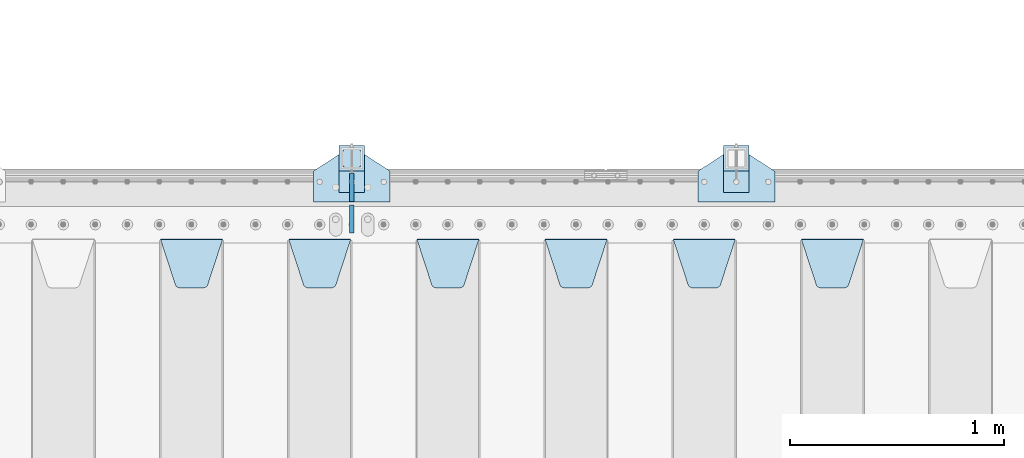
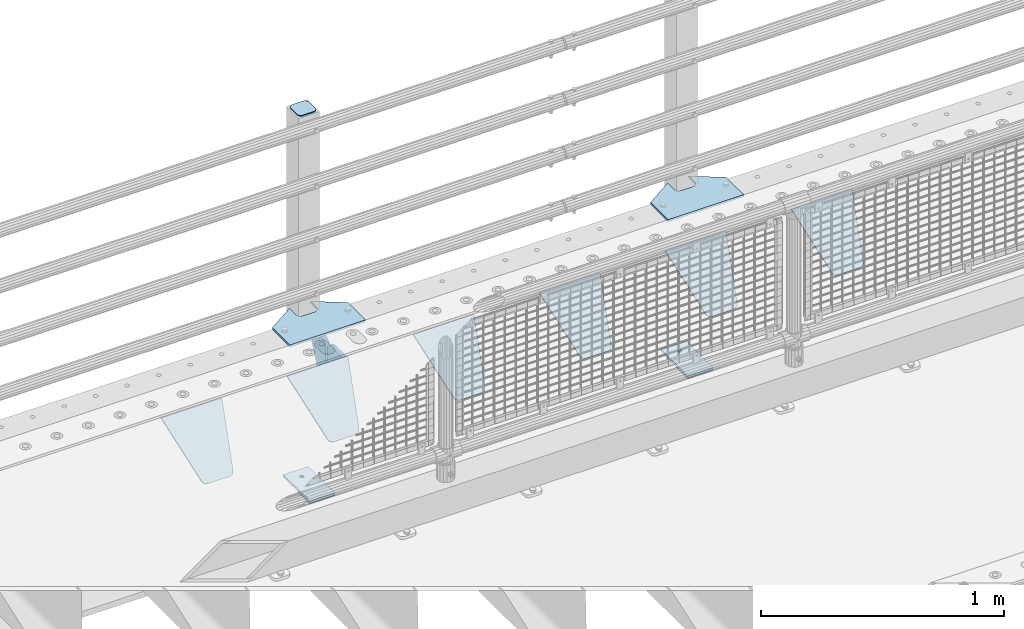
# One storey, part 163 of 193: 15 plates.
"""IFC2X3 building model written with IfcOpenShell, lengths in millimetres."""

from ifc_helpers import new_model, si_unit, frame, origin_with_axes, place, context, subcontext, project, spatial, faceted_brep, material, type_object, element, save


model = new_model("IFC2X3")

# Units and contexts
model_context = context("Model", 3, precision=1e-05, world=origin_with_axes())
body_context = subcontext(model_context, "Body", "Model", "MODEL_VIEW")
ifc_project = project(units=[si_unit("LENGTHUNIT", "METRE", prefix="MILLI"), si_unit("AREAUNIT", "SQUARE_METRE"), si_unit("VOLUMEUNIT", "CUBIC_METRE"), si_unit("MASSUNIT", "GRAM", prefix="KILO"), si_unit("TIMEUNIT", "SECOND"), si_unit("PLANEANGLEUNIT", "RADIAN"), si_unit("SOLIDANGLEUNIT", "STERADIAN"), si_unit("THERMODYNAMICTEMPERATUREUNIT", "DEGREE_CELSIUS"), si_unit("LUMINOUSINTENSITYUNIT", "LUMEN")], contexts=[model_context])

# Site, building, storey
site_placement = place(None, origin_with_axes())
site = spatial("IfcSite", under=ifc_project, at=site_placement, CompositionType="ELEMENT")
building_placement = place(site_placement, origin_with_axes())
building = spatial("IfcBuilding", under=site, at=building_placement, Name="Standard", CompositionType="ELEMENT")
storey_placement = place(building_placement, origin_with_axes())
storey = spatial("IfcBuildingStorey", under=building, at=storey_placement, Name="Undefined", CompositionType="ELEMENT", Elevation=0.0)

# Plates
ifc_material_1 = material(Name="STEEL/S355N")
plate_type_1 = type_object("IfcPlateType", PredefinedType="NOTDEFINED")
plate_1_placement = place(storey_placement, frame((-36195.0, 29831.767766956, -1.76776695296758), z_axis=(0.0, -0.707106781186547, -0.707106781186548), x_axis=(1.0, 0.0, 0.0)))
element("IfcPlate", 1, at=plate_1_placement, inside=storey, type_object=plate_type_1, material=ifc_material_1, context=body_context, shape_type="Brep", body=[
    faceted_brep([(0.0, -2.5, 0.0), (69.345504679477, -2.50000000000364, 300.171731424831), (69.345504679477, 2.49999999999636, 300.171731424831), (0.0, 2.5, 0.0), (70.9274061199576, -2.50000000000364, 304.897442415397), (70.9274061199576, 2.49999999999636, 304.897442415397), (73.3818627772307, -2.50000000000364, 309.234538108529), (73.3818627772307, 2.49999999999636, 309.234538108529), (76.6187032999551, -2.50000000000728, 313.023683126103), (76.6187032999551, 2.49999999999636, 313.023683126103), (80.5190132704993, -2.50000000000364, 316.125672595372), (80.5190132704993, 2.49999999999636, 316.125672595368), (84.9395038596849, -2.50000000000364, 318.426546230472), (84.9395038596849, 2.49999999999636, 318.426546230476), (89.7177759439219, -2.50000000000364, 319.841774983273), (89.7177759439219, 2.49999999999636, 319.841774983277), (94.678286292652, -2.50000000000364, 320.319366455074), (94.678286292652, 2.49999999999636, 320.319366455074), (195.321713707348, -2.50000000000364, 320.319366455074), (195.321713707348, 2.49999999999636, 320.319366455074), (200.282224056078, -2.50000000000364, 319.841774983273), (200.282224056078, 2.49999999999636, 319.841774983277), (205.060496140315, -2.50000000000364, 318.426546230472), (205.060496140315, 2.49999999999636, 318.426546230472), (209.480986729501, -2.50000000000364, 316.125672595372), (209.480986729501, 2.49999999999636, 316.125672595368), (213.381296700045, -2.50000000000728, 313.023683126103), (213.381296700045, 2.49999999999272, 313.023683126103), (216.618137222769, -2.50000000000364, 309.234538108525), (216.618137222769, 2.49999999999636, 309.234538108522), (219.072593880042, -2.50000000000364, 304.897442415397), (219.072593880042, 2.49999999999636, 304.897442415397), (220.654495320523, -2.50000000000364, 300.171731424831), (220.654495320523, 2.49999999999636, 300.171731424831), (290.0, -2.50000000000364, 0.0), (290.0, 2.49999999999636, 0.0)], [[[0, 1, 2, 3]], [[1, 4, 5, 2]], [[4, 6, 7, 5]], [[6, 8, 9, 7]], [[8, 10, 11, 9]], [[10, 12, 13, 11]], [[12, 14, 15, 13]], [[14, 16, 17, 15]], [[16, 18, 19, 17]], [[18, 20, 21, 19]], [[20, 22, 23, 21]], [[22, 24, 25, 23]], [[24, 26, 27, 25]], [[26, 28, 29, 27]], [[28, 30, 31, 29]], [[30, 32, 33, 31]], [[32, 34, 35, 33]], [[34, 0, 3, 35]], [[5, 7, 9, 11, 13, 15, 17, 19, 21, 23, 25, 27, 29, 31, 33, 35, 3, 2]], [[34, 32, 30, 28, 26, 24, 22, 20, 18, 16, 14, 12, 10, 8, 6, 4, 1, 0]]]),
])
plate_2_placement = place(storey_placement, frame((-36795.0, 29831.767766956, -1.76776695296758), z_axis=(0.0, -0.707106781186547, -0.707106781186548), x_axis=(1.0, 0.0, 0.0)))
element("IfcPlate", 2, at=plate_2_placement, inside=storey, type_object=plate_type_1, material=ifc_material_1, context=body_context, shape_type="Brep", body=[
    faceted_brep([(0.0, -2.5, 0.0), (69.345504679477, -2.50000000000364, 300.171731424831), (69.345504679477, 2.49999999999636, 300.171731424831), (0.0, 2.5, 0.0), (70.9274061199576, -2.50000000000364, 304.897442415397), (70.9274061199576, 2.49999999999636, 304.897442415397), (73.3818627772307, -2.50000000000364, 309.234538108529), (73.3818627772307, 2.49999999999636, 309.234538108529), (76.6187032999551, -2.50000000000728, 313.023683126103), (76.6187032999551, 2.49999999999636, 313.023683126103), (80.5190132704993, -2.50000000000364, 316.125672595372), (80.5190132704993, 2.49999999999636, 316.125672595368), (84.9395038596849, -2.50000000000364, 318.426546230472), (84.9395038596849, 2.49999999999636, 318.426546230476), (89.7177759439219, -2.50000000000364, 319.841774983273), (89.7177759439219, 2.49999999999636, 319.841774983277), (94.678286292652, -2.50000000000364, 320.319366455074), (94.678286292652, 2.49999999999636, 320.319366455074), (195.321713707348, -2.50000000000364, 320.319366455074), (195.321713707348, 2.49999999999636, 320.319366455074), (200.282224056078, -2.50000000000364, 319.841774983273), (200.282224056078, 2.49999999999636, 319.841774983277), (205.060496140315, -2.50000000000364, 318.426546230472), (205.060496140315, 2.49999999999636, 318.426546230472), (209.480986729501, -2.50000000000364, 316.125672595372), (209.480986729501, 2.49999999999636, 316.125672595368), (213.381296700045, -2.50000000000728, 313.023683126103), (213.381296700045, 2.49999999999272, 313.023683126103), (216.618137222769, -2.50000000000364, 309.234538108525), (216.618137222769, 2.49999999999636, 309.234538108522), (219.072593880042, -2.50000000000364, 304.897442415397), (219.072593880042, 2.49999999999636, 304.897442415397), (220.654495320523, -2.50000000000364, 300.171731424831), (220.654495320523, 2.49999999999636, 300.171731424831), (290.0, -2.50000000000364, 0.0), (290.0, 2.49999999999636, 0.0)], [[[0, 1, 2, 3]], [[1, 4, 5, 2]], [[4, 6, 7, 5]], [[6, 8, 9, 7]], [[8, 10, 11, 9]], [[10, 12, 13, 11]], [[12, 14, 15, 13]], [[14, 16, 17, 15]], [[16, 18, 19, 17]], [[18, 20, 21, 19]], [[20, 22, 23, 21]], [[22, 24, 25, 23]], [[24, 26, 27, 25]], [[26, 28, 29, 27]], [[28, 30, 31, 29]], [[30, 32, 33, 31]], [[32, 34, 35, 33]], [[34, 0, 3, 35]], [[5, 7, 9, 11, 13, 15, 17, 19, 21, 23, 25, 27, 29, 31, 33, 35, 3, 2]], [[34, 32, 30, 28, 26, 24, 22, 20, 18, 16, 14, 12, 10, 8, 6, 4, 1, 0]]]),
])
plate_3_placement = place(storey_placement, frame((-37395.0, 29831.767766956, -1.76776695296758), z_axis=(0.0, -0.707106781186547, -0.707106781186548), x_axis=(1.0, 0.0, 0.0)))
element("IfcPlate", 3, at=plate_3_placement, inside=storey, type_object=plate_type_1, material=ifc_material_1, context=body_context, shape_type="Brep", body=[
    faceted_brep([(0.0, -2.5, 0.0), (69.345504679477, -2.50000000000364, 300.171731424831), (69.345504679477, 2.49999999999636, 300.171731424831), (0.0, 2.5, 0.0), (70.9274061199576, -2.50000000000364, 304.897442415397), (70.9274061199576, 2.49999999999636, 304.897442415397), (73.3818627772307, -2.50000000000364, 309.234538108529), (73.3818627772307, 2.49999999999636, 309.234538108529), (76.6187032999551, -2.50000000000728, 313.023683126103), (76.6187032999551, 2.49999999999636, 313.023683126103), (80.5190132704993, -2.50000000000364, 316.125672595372), (80.5190132704993, 2.49999999999636, 316.125672595368), (84.9395038596849, -2.50000000000364, 318.426546230472), (84.9395038596849, 2.49999999999636, 318.426546230476), (89.7177759439219, -2.50000000000364, 319.841774983273), (89.7177759439219, 2.49999999999636, 319.841774983277), (94.678286292652, -2.50000000000364, 320.319366455074), (94.678286292652, 2.49999999999636, 320.319366455074), (195.321713707348, -2.50000000000364, 320.319366455074), (195.321713707348, 2.49999999999636, 320.319366455074), (200.282224056078, -2.50000000000364, 319.841774983273), (200.282224056078, 2.49999999999636, 319.841774983277), (205.060496140315, -2.50000000000364, 318.426546230472), (205.060496140315, 2.49999999999636, 318.426546230472), (209.480986729501, -2.50000000000364, 316.125672595372), (209.480986729501, 2.49999999999636, 316.125672595368), (213.381296700045, -2.50000000000728, 313.023683126103), (213.381296700045, 2.49999999999272, 313.023683126103), (216.618137222769, -2.50000000000364, 309.234538108525), (216.618137222769, 2.49999999999636, 309.234538108522), (219.072593880042, -2.50000000000364, 304.897442415397), (219.072593880042, 2.49999999999636, 304.897442415397), (220.654495320523, -2.50000000000364, 300.171731424831), (220.654495320523, 2.49999999999636, 300.171731424831), (290.0, -2.50000000000364, 0.0), (290.0, 2.49999999999636, 0.0)], [[[0, 1, 2, 3]], [[1, 4, 5, 2]], [[4, 6, 7, 5]], [[6, 8, 9, 7]], [[8, 10, 11, 9]], [[10, 12, 13, 11]], [[12, 14, 15, 13]], [[14, 16, 17, 15]], [[16, 18, 19, 17]], [[18, 20, 21, 19]], [[20, 22, 23, 21]], [[22, 24, 25, 23]], [[24, 26, 27, 25]], [[26, 28, 29, 27]], [[28, 30, 31, 29]], [[30, 32, 33, 31]], [[32, 34, 35, 33]], [[34, 0, 3, 35]], [[5, 7, 9, 11, 13, 15, 17, 19, 21, 23, 25, 27, 29, 31, 33, 35, 3, 2]], [[34, 32, 30, 28, 26, 24, 22, 20, 18, 16, 14, 12, 10, 8, 6, 4, 1, 0]]]),
])
plate_4_placement = place(storey_placement, frame((-37995.0, 29831.767766956, -1.76776695296758), z_axis=(0.0, -0.707106781186547, -0.707106781186548), x_axis=(1.0, 0.0, 0.0)))
element("IfcPlate", 4, at=plate_4_placement, inside=storey, type_object=plate_type_1, material=ifc_material_1, context=body_context, shape_type="Brep", body=[
    faceted_brep([(0.0, -2.5, 0.0), (69.345504679477, -2.50000000000364, 300.171731424831), (69.345504679477, 2.49999999999636, 300.171731424831), (0.0, 2.5, 0.0), (70.9274061199576, -2.50000000000364, 304.897442415397), (70.9274061199576, 2.49999999999636, 304.897442415397), (73.3818627772307, -2.50000000000364, 309.234538108529), (73.3818627772307, 2.49999999999636, 309.234538108529), (76.6187032999551, -2.50000000000728, 313.023683126103), (76.6187032999551, 2.49999999999636, 313.023683126103), (80.5190132704993, -2.50000000000364, 316.125672595372), (80.5190132704993, 2.49999999999636, 316.125672595368), (84.9395038596849, -2.50000000000364, 318.426546230472), (84.9395038596849, 2.49999999999636, 318.426546230476), (89.7177759439219, -2.50000000000364, 319.841774983273), (89.7177759439219, 2.49999999999636, 319.841774983277), (94.678286292652, -2.50000000000364, 320.319366455074), (94.678286292652, 2.49999999999636, 320.319366455074), (195.321713707348, -2.50000000000364, 320.319366455074), (195.321713707348, 2.49999999999636, 320.319366455074), (200.282224056078, -2.50000000000364, 319.841774983273), (200.282224056078, 2.49999999999636, 319.841774983277), (205.060496140315, -2.50000000000364, 318.426546230472), (205.060496140315, 2.49999999999636, 318.426546230472), (209.480986729501, -2.50000000000364, 316.125672595372), (209.480986729501, 2.49999999999636, 316.125672595368), (213.381296700045, -2.50000000000728, 313.023683126103), (213.381296700045, 2.49999999999272, 313.023683126103), (216.618137222769, -2.50000000000364, 309.234538108525), (216.618137222769, 2.49999999999636, 309.234538108522), (219.072593880042, -2.50000000000364, 304.897442415397), (219.072593880042, 2.49999999999636, 304.897442415397), (220.654495320523, -2.50000000000364, 300.171731424831), (220.654495320523, 2.49999999999636, 300.171731424831), (290.0, -2.50000000000364, 0.0), (290.0, 2.49999999999636, 0.0)], [[[0, 1, 2, 3]], [[1, 4, 5, 2]], [[4, 6, 7, 5]], [[6, 8, 9, 7]], [[8, 10, 11, 9]], [[10, 12, 13, 11]], [[12, 14, 15, 13]], [[14, 16, 17, 15]], [[16, 18, 19, 17]], [[18, 20, 21, 19]], [[20, 22, 23, 21]], [[22, 24, 25, 23]], [[24, 26, 27, 25]], [[26, 28, 29, 27]], [[28, 30, 31, 29]], [[30, 32, 33, 31]], [[32, 34, 35, 33]], [[34, 0, 3, 35]], [[5, 7, 9, 11, 13, 15, 17, 19, 21, 23, 25, 27, 29, 31, 33, 35, 3, 2]], [[34, 32, 30, 28, 26, 24, 22, 20, 18, 16, 14, 12, 10, 8, 6, 4, 1, 0]]]),
])
plate_5_placement = place(storey_placement, frame((-38595.0, 29831.767766956, -1.76776695296758), z_axis=(0.0, -0.707106781186547, -0.707106781186548), x_axis=(1.0, 0.0, 0.0)))
element("IfcPlate", 5, at=plate_5_placement, inside=storey, type_object=plate_type_1, material=ifc_material_1, context=body_context, shape_type="Brep", body=[
    faceted_brep([(0.0, -2.5, 0.0), (69.345504679477, -2.50000000000364, 300.171731424831), (69.345504679477, 2.49999999999636, 300.171731424831), (0.0, 2.5, 0.0), (70.9274061199576, -2.50000000000364, 304.897442415397), (70.9274061199576, 2.49999999999636, 304.897442415397), (73.3818627772307, -2.50000000000364, 309.234538108529), (73.3818627772307, 2.49999999999636, 309.234538108529), (76.6187032999551, -2.50000000000728, 313.023683126103), (76.6187032999551, 2.49999999999636, 313.023683126103), (80.5190132704993, -2.50000000000364, 316.125672595372), (80.5190132704993, 2.49999999999636, 316.125672595368), (84.9395038596849, -2.50000000000364, 318.426546230472), (84.9395038596849, 2.49999999999636, 318.426546230476), (89.7177759439219, -2.50000000000364, 319.841774983273), (89.7177759439219, 2.49999999999636, 319.841774983277), (94.678286292652, -2.50000000000364, 320.319366455074), (94.678286292652, 2.49999999999636, 320.319366455074), (195.321713707348, -2.50000000000364, 320.319366455074), (195.321713707348, 2.49999999999636, 320.319366455074), (200.282224056078, -2.50000000000364, 319.841774983273), (200.282224056078, 2.49999999999636, 319.841774983277), (205.060496140315, -2.50000000000364, 318.426546230472), (205.060496140315, 2.49999999999636, 318.426546230472), (209.480986729501, -2.50000000000364, 316.125672595372), (209.480986729501, 2.49999999999636, 316.125672595368), (213.381296700045, -2.50000000000728, 313.023683126103), (213.381296700045, 2.49999999999272, 313.023683126103), (216.618137222769, -2.50000000000364, 309.234538108525), (216.618137222769, 2.49999999999636, 309.234538108522), (219.072593880042, -2.50000000000364, 304.897442415397), (219.072593880042, 2.49999999999636, 304.897442415397), (220.654495320523, -2.50000000000364, 300.171731424831), (220.654495320523, 2.49999999999636, 300.171731424831), (290.0, -2.50000000000364, 0.0), (290.0, 2.49999999999636, 0.0)], [[[0, 1, 2, 3]], [[1, 4, 5, 2]], [[4, 6, 7, 5]], [[6, 8, 9, 7]], [[8, 10, 11, 9]], [[10, 12, 13, 11]], [[12, 14, 15, 13]], [[14, 16, 17, 15]], [[16, 18, 19, 17]], [[18, 20, 21, 19]], [[20, 22, 23, 21]], [[22, 24, 25, 23]], [[24, 26, 27, 25]], [[26, 28, 29, 27]], [[28, 30, 31, 29]], [[30, 32, 33, 31]], [[32, 34, 35, 33]], [[34, 0, 3, 35]], [[5, 7, 9, 11, 13, 15, 17, 19, 21, 23, 25, 27, 29, 31, 33, 35, 3, 2]], [[34, 32, 30, 28, 26, 24, 22, 20, 18, 16, 14, 12, 10, 8, 6, 4, 1, 0]]]),
])
plate_6_placement = place(storey_placement, frame((-39195.0, 29831.767766956, -1.76776695296758), z_axis=(0.0, -0.707106781186547, -0.707106781186548), x_axis=(1.0, 0.0, 0.0)))
element("IfcPlate", 6, at=plate_6_placement, inside=storey, type_object=plate_type_1, material=ifc_material_1, context=body_context, shape_type="Brep", body=[
    faceted_brep([(0.0, -2.5, 0.0), (69.345504679477, -2.50000000000364, 300.171731424831), (69.345504679477, 2.49999999999636, 300.171731424831), (0.0, 2.5, 0.0), (70.9274061199576, -2.50000000000364, 304.897442415397), (70.9274061199576, 2.49999999999636, 304.897442415397), (73.3818627772307, -2.50000000000364, 309.234538108529), (73.3818627772307, 2.49999999999636, 309.234538108529), (76.6187032999551, -2.50000000000728, 313.023683126103), (76.6187032999551, 2.49999999999636, 313.023683126103), (80.5190132704993, -2.50000000000364, 316.125672595372), (80.5190132704993, 2.49999999999636, 316.125672595368), (84.9395038596849, -2.50000000000364, 318.426546230472), (84.9395038596849, 2.49999999999636, 318.426546230476), (89.7177759439219, -2.50000000000364, 319.841774983273), (89.7177759439219, 2.49999999999636, 319.841774983277), (94.678286292652, -2.50000000000364, 320.319366455074), (94.678286292652, 2.49999999999636, 320.319366455074), (195.321713707348, -2.50000000000364, 320.319366455074), (195.321713707348, 2.49999999999636, 320.319366455074), (200.282224056078, -2.50000000000364, 319.841774983273), (200.282224056078, 2.49999999999636, 319.841774983277), (205.060496140315, -2.50000000000364, 318.426546230472), (205.060496140315, 2.49999999999636, 318.426546230472), (209.480986729501, -2.50000000000364, 316.125672595372), (209.480986729501, 2.49999999999636, 316.125672595368), (213.381296700045, -2.50000000000728, 313.023683126103), (213.381296700045, 2.49999999999272, 313.023683126103), (216.618137222769, -2.50000000000364, 309.234538108525), (216.618137222769, 2.49999999999636, 309.234538108522), (219.072593880042, -2.50000000000364, 304.897442415397), (219.072593880042, 2.49999999999636, 304.897442415397), (220.654495320523, -2.50000000000364, 300.171731424831), (220.654495320523, 2.49999999999636, 300.171731424831), (290.0, -2.50000000000364, 0.0), (290.0, 2.49999999999636, 0.0)], [[[0, 1, 2, 3]], [[1, 4, 5, 2]], [[4, 6, 7, 5]], [[6, 8, 9, 7]], [[8, 10, 11, 9]], [[10, 12, 13, 11]], [[12, 14, 15, 13]], [[14, 16, 17, 15]], [[16, 18, 19, 17]], [[18, 20, 21, 19]], [[20, 22, 23, 21]], [[22, 24, 25, 23]], [[24, 26, 27, 25]], [[26, 28, 29, 27]], [[28, 30, 31, 29]], [[30, 32, 33, 31]], [[32, 34, 35, 33]], [[34, 0, 3, 35]], [[5, 7, 9, 11, 13, 15, 17, 19, 21, 23, 25, 27, 29, 31, 33, 35, 3, 2]], [[34, 32, 30, 28, 26, 24, 22, 20, 18, 16, 14, 12, 10, 8, 6, 4, 1, 0]]]),
])
plate_type_2 = type_object("IfcPlateType", PredefinedType="NOTDEFINED")
for number, where, z_axis, x_axis in (
    (7, (-38300.0, 29860.0, -30.0), (0.0, 0.0, -1.0), (0.0, 1.0, 0.0)),
    (8, (-38300.0, 30140.0, -30.0), (0.0, 0.0, -1.0), (0.0, -1.0, 0.0)),
):
    element("IfcPlate", number, at=place(storey_placement, frame(where, z_axis=z_axis, x_axis=x_axis)), inside=storey, type_object=plate_type_2, material=ifc_material_1, context=body_context, shape_type="Brep", body=[
        faceted_brep([(0.0, -10.0, 0.0), (0.0, -10.0, 30.0), (0.0, 10.0, 30.0), (0.0, 10.0, 0.0), (102.0, -10.0, 250.0), (102.0, 10.0, 250.0), (132.0, -10.0, 250.0), (132.0, 10.0, 250.0), (132.0, -10.0, 30.0), (132.0, 10.0, 30.0), (131.544232590368, -10.0, 24.790554669992), (131.544232590368, 10.0, 24.790554669992), (130.190778623579, -10.0, 19.7393957002299), (130.190778623579, 10.0, 19.7393957002299), (127.980762113533, -10.0, 15.0), (127.980762113533, 10.0, 15.0), (124.98133329357, -10.0, 10.7163717094038), (124.98133329357, 10.0, 10.7163717094038), (121.283628290596, -10.0, 7.01866670643062), (121.283628290596, 10.0, 7.01866670643062), (117.0, -10.0, 4.01923788646684), (117.0, 10.0, 4.01923788646684), (112.260604299769, -10.0, 1.80922137642278), (112.260604299769, 10.0, 1.80922137642278), (107.209445330009, -10.0, 0.455767409633722), (107.209445330009, 10.0, 0.455767409633722), (102.0, -10.0, 0.0), (102.0, 10.0, 0.0)], [[[0, 1, 2, 3]], [[1, 4, 5, 2]], [[4, 6, 7, 5]], [[6, 8, 9, 7]], [[8, 10, 11, 9]], [[10, 12, 13, 11]], [[12, 14, 15, 13]], [[14, 16, 17, 15]], [[16, 18, 19, 17]], [[18, 20, 21, 19]], [[20, 22, 23, 21]], [[22, 24, 25, 23]], [[24, 26, 27, 25]], [[26, 0, 3, 27]], [[5, 7, 9, 11, 13, 15, 17, 19, 21, 23, 25, 27, 3, 2]], [[26, 24, 22, 20, 18, 16, 14, 12, 10, 8, 6, 4, 1, 0]]]),
    ])
ifc_material_2 = material(Name="STEEL/S355J2")
plate_type_3 = type_object("IfcPlateType", PredefinedType="NOTDEFINED")
plate_7_placement = place(storey_placement, frame((-36680.0, 30005.0, 5.00000000004911), z_axis=(0.0, 1.0, 0.0), x_axis=(1.0, 0.0, 0.0)))
element("IfcPlate", 9, at=plate_7_placement, inside=storey, type_object=plate_type_3, material=ifc_material_2, context=body_context, shape_type="Brep", body=[
    faceted_brep([(0.0, -5.0, 0.0), (2.31396552408114e-06, -5.0, 145.0), (2.31396552408114e-06, 5.0, 145.0), (0.0, 5.0, 0.0), (130.0, -5.0, 230.0), (130.0, 5.0, 230.0), (130.0, -5.0, 180.0), (130.0, 5.0, 180.0), (130.48036798992, -5.0, 175.122741949595), (130.48036798992, 5.0, 175.122741949595), (131.903011687216, -5.0, 170.432914190871), (131.903011687216, 5.0, 170.432914190871), (134.213259692435, -5.0, 166.110744174512), (134.213259692435, 5.0, 166.110744174512), (137.322330470335, -5.0, 162.322330470335), (137.322330470335, 5.0, 162.322330470335), (141.110744174512, -5.0, 159.213259692435), (141.110744174512, 5.0, 159.213259692435), (145.432914190871, -5.0, 156.903011687216), (145.432914190871, 5.0, 156.903011687216), (150.122741949595, -5.0, 155.48036798992), (150.122741949595, 5.0, 155.48036798992), (155.0, -5.0, 155.0), (155.0, 5.0, 155.0), (205.0, -5.0, 155.0), (205.0, 5.0, 155.0), (209.877258050405, -5.0, 155.48036798992), (209.877258050405, 5.0, 155.48036798992), (214.567085809129, -5.0, 156.903011687216), (214.567085809129, 5.0, 156.903011687216), (218.889255825488, -5.0, 159.213259692435), (218.889255825488, 5.0, 159.213259692435), (222.677669529665, -5.0, 162.322330470335), (222.677669529665, 5.0, 162.322330470335), (225.786740307565, -5.0, 166.110744174512), (225.786740307565, 5.0, 166.110744174512), (228.096988312784, -5.0, 170.432914190871), (228.096988312784, 5.0, 170.432914190871), (229.51963201008, -5.0, 175.122741949595), (229.51963201008, 5.0, 175.122741949595), (230.0, -5.0, 180.0), (230.0, 5.0, 180.0), (230.0, -5.0, 230.0), (230.0, 5.0, 230.0), (360.0, -5.0, 145.0), (360.0, 5.0, 145.0), (360.0, -5.0, -7.27595761418343e-12), (360.0, 5.0, -7.27595761418343e-12)], [[[0, 1, 2, 3]], [[1, 4, 5, 2]], [[4, 6, 7, 5]], [[6, 8, 9, 7]], [[8, 10, 11, 9]], [[10, 12, 13, 11]], [[12, 14, 15, 13]], [[14, 16, 17, 15]], [[16, 18, 19, 17]], [[18, 20, 21, 19]], [[20, 22, 23, 21]], [[22, 24, 25, 23]], [[24, 26, 27, 25]], [[26, 28, 29, 27]], [[28, 30, 31, 29]], [[30, 32, 33, 31]], [[32, 34, 35, 33]], [[34, 36, 37, 35]], [[36, 38, 39, 37]], [[38, 40, 41, 39]], [[40, 42, 43, 41]], [[42, 44, 45, 43]], [[44, 46, 47, 45]], [[46, 0, 3, 47]], [[5, 7, 9, 11, 13, 15, 17, 19, 21, 23, 25, 27, 29, 31, 33, 35, 37, 39, 41, 43, 45, 47, 3, 2]], [[46, 44, 42, 40, 38, 36, 34, 32, 30, 28, 26, 24, 22, 20, 18, 16, 14, 12, 10, 8, 6, 4, 1, 0]]]),
])
plate_8_placement = place(storey_placement, frame((-38480.0, 30005.0, 5.00000000004911), z_axis=(0.0, 1.0, 0.0), x_axis=(1.0, 0.0, 0.0)))
element("IfcPlate", 10, at=plate_8_placement, inside=storey, type_object=plate_type_3, material=ifc_material_2, context=body_context, shape_type="Brep", body=[
    faceted_brep([(0.0, -5.0, 0.0), (2.31396552408114e-06, -5.0, 145.0), (2.31396552408114e-06, 5.0, 145.0), (0.0, 5.0, 0.0), (130.0, -5.0, 230.0), (130.0, 5.0, 230.0), (130.0, -5.0, 180.0), (130.0, 5.0, 180.0), (130.48036798992, -5.0, 175.122741949595), (130.48036798992, 5.0, 175.122741949595), (131.903011687216, -5.0, 170.432914190871), (131.903011687216, 5.0, 170.432914190871), (134.213259692435, -5.0, 166.110744174512), (134.213259692435, 5.0, 166.110744174512), (137.322330470335, -5.0, 162.322330470335), (137.322330470335, 5.0, 162.322330470335), (141.110744174512, -5.0, 159.213259692435), (141.110744174512, 5.0, 159.213259692435), (145.432914190871, -5.0, 156.903011687216), (145.432914190871, 5.0, 156.903011687216), (150.122741949595, -5.0, 155.48036798992), (150.122741949595, 5.0, 155.48036798992), (155.0, -5.0, 155.0), (155.0, 5.0, 155.0), (205.0, -5.0, 155.0), (205.0, 5.0, 155.0), (209.877258050405, -5.0, 155.48036798992), (209.877258050405, 5.0, 155.48036798992), (214.567085809129, -5.0, 156.903011687216), (214.567085809129, 5.0, 156.903011687216), (218.889255825488, -5.0, 159.213259692435), (218.889255825488, 5.0, 159.213259692435), (222.677669529665, -5.0, 162.322330470335), (222.677669529665, 5.0, 162.322330470335), (225.786740307565, -5.0, 166.110744174512), (225.786740307565, 5.0, 166.110744174512), (228.096988312784, -5.0, 170.432914190871), (228.096988312784, 5.0, 170.432914190871), (229.51963201008, -5.0, 175.122741949595), (229.51963201008, 5.0, 175.122741949595), (230.0, -5.0, 180.0), (230.0, 5.0, 180.0), (230.0, -5.0, 230.0), (230.0, 5.0, 230.0), (360.0, -5.0, 145.0), (360.0, 5.0, 145.0), (360.0, -5.0, -7.27595761418343e-12), (360.0, 5.0, -7.27595761418343e-12)], [[[0, 1, 2, 3]], [[1, 4, 5, 2]], [[4, 6, 7, 5]], [[6, 8, 9, 7]], [[8, 10, 11, 9]], [[10, 12, 13, 11]], [[12, 14, 15, 13]], [[14, 16, 17, 15]], [[16, 18, 19, 17]], [[18, 20, 21, 19]], [[20, 22, 23, 21]], [[22, 24, 25, 23]], [[24, 26, 27, 25]], [[26, 28, 29, 27]], [[28, 30, 31, 29]], [[30, 32, 33, 31]], [[32, 34, 35, 33]], [[34, 36, 37, 35]], [[36, 38, 39, 37]], [[38, 40, 41, 39]], [[40, 42, 43, 41]], [[42, 44, 45, 43]], [[44, 46, 47, 45]], [[46, 0, 3, 47]], [[5, 7, 9, 11, 13, 15, 17, 19, 21, 23, 25, 27, 29, 31, 33, 35, 37, 39, 41, 43, 45, 47, 3, 2]], [[46, 44, 42, 40, 38, 36, 34, 32, 30, 28, 26, 24, 22, 20, 18, 16, 14, 12, 10, 8, 6, 4, 1, 0]]]),
])
plate_type_4 = type_object("IfcPlateType", PredefinedType="NOTDEFINED")
for number, where, z_axis, x_axis in (
    (11, (-36559.9999999999, 30050.0000000002, -850.000000000002), (0.0, 1.0, 0.0), (1.0, 0.0, 0.0)),
    (12, (-38359.9999999999, 30050.0000000002, -850.000000000002), (0.0, 1.0, 0.0), (1.0, 0.0, 0.0)),
):
    element("IfcPlate", number, at=place(storey_placement, frame(where, z_axis=z_axis, x_axis=x_axis)), inside=storey, type_object=plate_type_4, material=ifc_material_2, context=body_context, shape_type="Brep", body=[
        faceted_brep([(66.3639610305399, -5.0, 163.636038969111), (66.3639610305399, 5.0, 163.636038969111), (59.9999999998618, 5.0, 160.999999999789), (59.9999999998618, -5.0, 160.999999999789), (53.6360389691836, 5.0, 163.636038969111), (53.6360389691836, -5.0, 163.636038969111), (50.9999999998618, 5.0, 169.999999999789), (50.9999999998618, -5.0, 169.999999999789), (53.6360389691836, 5.0, 176.363961030467), (53.6360389691836, -5.0, 176.363961030467), (59.9999999998618, 5.0, 178.999999999789), (59.9999999998618, -5.0, 178.999999999789), (66.3639610305399, 5.0, 176.363961030467), (66.3639610305399, -5.0, 176.363961030467), (68.9999999998618, 5.0, 169.999999999789), (68.9999999998618, -5.0, 169.999999999789), (120.0, -5.0, 0.0), (120.0, -5.0, 220.0), (0.0, -5.0, 220.0), (0.0, -5.0, 0.0), (0.0, 5.0, 0.0), (120.0, 5.0, 0.0), (120.0, 5.0, 220.0), (0.0, 5.0, 220.0)], [[[0, 1, 2, 3]], [[3, 2, 4, 5]], [[5, 4, 6, 7]], [[7, 6, 8, 9]], [[9, 8, 10, 11]], [[11, 10, 12, 13]], [[13, 12, 14, 15]], [[15, 14, 1, 0]], [[16, 17, 18, 19], [3, 5, 7, 9, 11, 13, 15, 0]], [[16, 19, 20, 21]], [[17, 16, 21, 22]], [[18, 17, 22, 23]], [[19, 18, 23, 20]], [[22, 21, 20, 23], [10, 8, 6, 4, 2, 1, 14, 12]]]),
    ])
plate_type_5 = type_object("IfcPlateType", PredefinedType="NOTDEFINED")
plate_9_placement = place(storey_placement, frame((-38255.9999999999, 30166.0000000002, 1012.50000000001), z_axis=(0.0, 1.0, 0.0), x_axis=(-1.0, 0.0, 0.0)))
element("IfcPlate", 13, at=plate_9_placement, inside=storey, type_object=plate_type_5, material=ifc_material_2, context=body_context, shape_type="Brep", body=[
    faceted_brep([(0.0, -2.5, 19.0), (0.0, -2.5, 69.0), (0.0, 2.5, 69.0), (0.0, 2.5, 19.0), (0.476369668544066, -2.5, 73.2278977451715), (0.476369668544066, 2.5, 73.2278977451715), (1.88159150985302, -2.5, 77.2437910432345), (1.88159150985302, 2.5, 77.2437910432345), (4.14520183310742, -2.5, 80.8463062353148), (4.14520183310742, 2.5, 80.8463062353148), (7.15369376468516, -2.5, 83.8547981668926), (7.15369376468516, 2.5, 83.8547981668926), (10.7562089567655, -2.5, 86.118408490147), (10.7562089567655, 2.5, 86.118408490147), (14.7721022548285, -2.5, 87.5236303314559), (14.7721022548285, 2.5, 87.5236303314559), (19.0, -2.5, 88.0), (19.0, 2.5, 88.0), (69.0, -2.5, 88.0), (69.0, 2.5, 88.0), (73.2278977451715, -2.5, 87.5236303314559), (73.2278977451715, 2.5, 87.5236303314559), (77.2437910432345, -2.5, 86.118408490147), (77.2437910432345, 2.5, 86.118408490147), (80.8463062353148, -2.5, 83.8547981668926), (80.8463062353148, 2.5, 83.8547981668926), (83.8547981668926, -2.5, 80.8463062353148), (83.8547981668926, 2.5, 80.8463062353148), (86.118408490147, -2.5, 77.2437910432345), (86.118408490147, 2.5, 77.2437910432345), (87.5236303314559, -2.5, 73.2278977451715), (87.5236303314559, 2.5, 73.2278977451715), (88.0, -2.5, 69.0), (88.0, 2.5, 69.0), (88.0, -2.5, 19.0), (88.0, 2.5, 19.0), (87.5236303314559, -2.5, 14.7721022548285), (87.5236303314559, 2.5, 14.7721022548285), (86.118408490147, -2.5, 10.7562089567655), (86.118408490147, 2.5, 10.7562089567655), (83.8547981668926, -2.5, 7.15369376468516), (83.8547981668926, 2.5, 7.15369376468516), (80.8463062353148, -2.5, 4.14520183310742), (80.8463062353148, 2.5, 4.14520183310742), (77.2437910432345, -2.5, 1.88159150985302), (77.2437910432345, 2.5, 1.88159150985302), (73.2278977451715, -2.5, 0.476369668544066), (73.2278977451715, 2.5, 0.476369668544066), (69.0, -2.5, 0.0), (69.0, 2.5, 0.0), (19.0, -2.5, 0.0), (19.0, 2.5, 0.0), (14.7721022548285, -2.5, 0.476369668544066), (14.7721022548285, 2.5, 0.476369668544066), (10.7562089567655, -2.5, 1.88159150985302), (10.7562089567655, 2.5, 1.88159150985302), (7.15369376468516, -2.5, 4.14520183310742), (7.15369376468516, 2.5, 4.14520183310742), (4.14520183310742, -2.5, 7.15369376468516), (4.14520183310742, 2.5, 7.15369376468516), (1.88159150985302, -2.5, 10.7562089567655), (1.88159150985302, 2.5, 10.7562089567655), (0.476369668544066, -2.5, 14.7721022548285), (0.476369668544066, 2.5, 14.7721022548285)], [[[0, 1, 2, 3]], [[1, 4, 5, 2]], [[4, 6, 7, 5]], [[6, 8, 9, 7]], [[8, 10, 11, 9]], [[10, 12, 13, 11]], [[12, 14, 15, 13]], [[14, 16, 17, 15]], [[16, 18, 19, 17]], [[18, 20, 21, 19]], [[20, 22, 23, 21]], [[22, 24, 25, 23]], [[24, 26, 27, 25]], [[26, 28, 29, 27]], [[28, 30, 31, 29]], [[30, 32, 33, 31]], [[32, 34, 35, 33]], [[34, 36, 37, 35]], [[36, 38, 39, 37]], [[38, 40, 41, 39]], [[40, 42, 43, 41]], [[42, 44, 45, 43]], [[44, 46, 47, 45]], [[46, 48, 49, 47]], [[48, 50, 51, 49]], [[50, 52, 53, 51]], [[52, 54, 55, 53]], [[54, 56, 57, 55]], [[56, 58, 59, 57]], [[58, 60, 61, 59]], [[60, 62, 63, 61]], [[62, 0, 3, 63]], [[5, 7, 9, 11, 13, 15, 17, 19, 21, 23, 25, 27, 29, 31, 33, 35, 37, 39, 41, 43, 45, 47, 49, 51, 53, 55, 57, 59, 61, 63, 3, 2]], [[62, 60, 58, 56, 54, 52, 50, 48, 46, 44, 42, 40, 38, 36, 34, 32, 30, 28, 26, 24, 22, 20, 18, 16, 14, 12, 10, 8, 6, 4, 1, 0]]]),
])
plate_type_6 = type_object("IfcPlateType", PredefinedType="NOTDEFINED")
for number, where, z_axis, x_axis in (
    (14, (-36559.9999999999, 30050.0000000002, -857.500000000002), (0.0, 1.0, 0.0), (1.0, 0.0, 0.0)),
    (15, (-38359.9999999999, 30050.0000000002, -857.500000000002), (0.0, 1.0, 0.0), (1.0, 0.0, 0.0)),
):
    element("IfcPlate", number, at=place(storey_placement, frame(where, z_axis=z_axis, x_axis=x_axis)), inside=storey, type_object=plate_type_6, material=ifc_material_2, context=body_context, shape_type="Brep", body=[
        faceted_brep([(0.0, -2.5, 0.0), (0.0, -2.5, 100.0), (0.0, 2.5, 100.0), (0.0, 2.5, 0.0), (120.0, -2.5, 100.0), (120.0, 2.5, 100.0), (120.0, -2.5, 0.0), (120.0, 2.5, 0.0)], [[[0, 1, 2, 3]], [[1, 4, 5, 2]], [[4, 6, 7, 5]], [[6, 0, 3, 7]], [[5, 7, 3, 2]], [[6, 4, 1, 0]]]),
    ])

save(model, "model.ifc")
